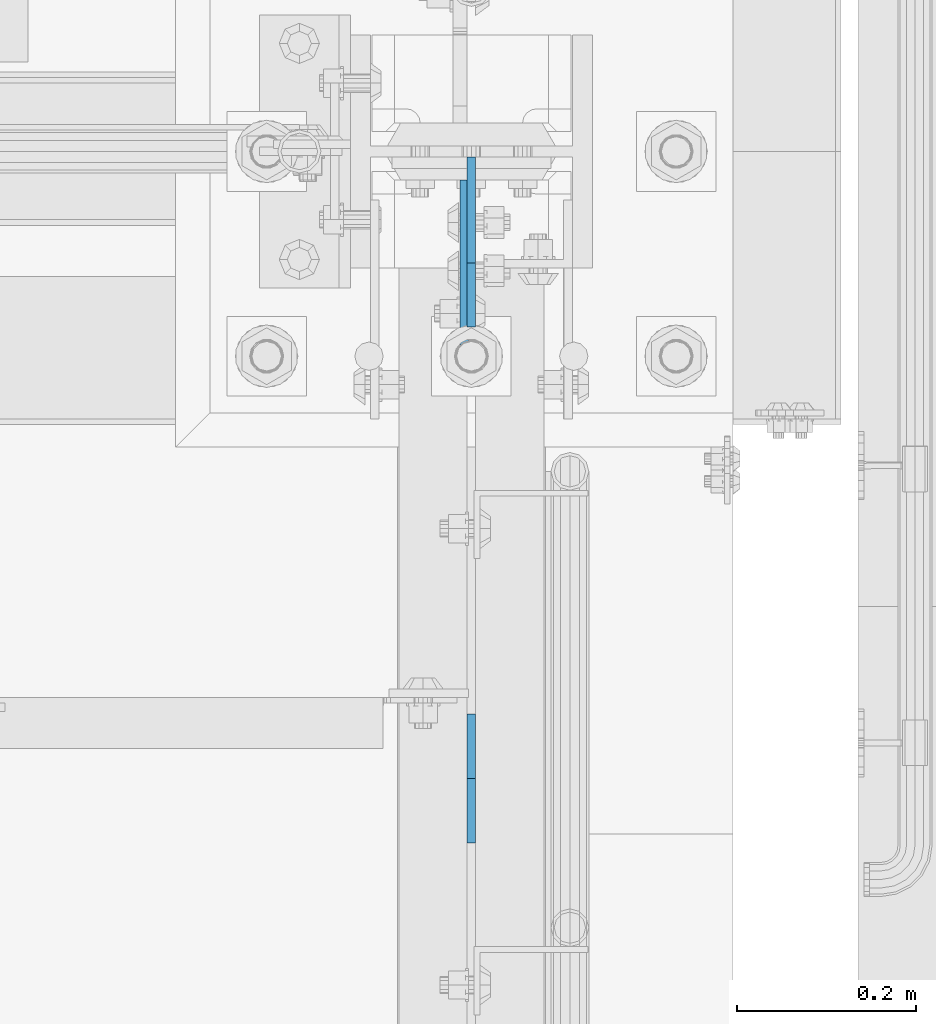
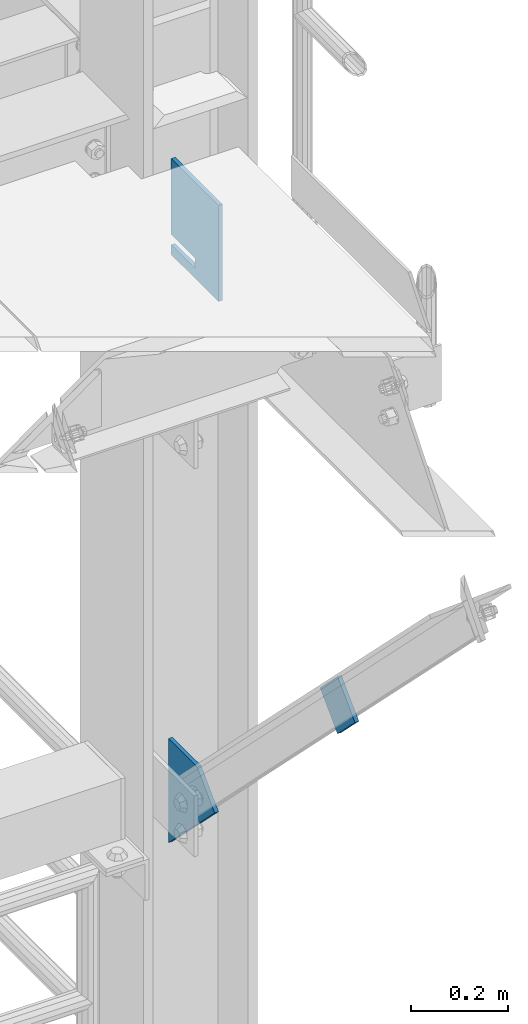
# One storey, part 1519 of 1876: 3 plates, 2 elements without a shape of their own.
"""IFC2X3 building model written with IfcOpenShell, lengths in millimetres."""

from ifc_helpers import new_model, si_unit, frame, origin_with_axes, place, context, subcontext, project, spatial, faceted_brep, material, type_object, element, aggregate, save


model = new_model("IFC2X3")

# Units and contexts
model_context = context("Model", 3, precision=1e-05, world=origin_with_axes())
body_context = subcontext(model_context, "Body", "Model", "MODEL_VIEW")
ifc_project = project(units=[si_unit("LENGTHUNIT", "METRE", prefix="MILLI"), si_unit("AREAUNIT", "SQUARE_METRE"), si_unit("VOLUMEUNIT", "CUBIC_METRE"), si_unit("MASSUNIT", "GRAM", prefix="KILO"), si_unit("TIMEUNIT", "SECOND"), si_unit("PLANEANGLEUNIT", "RADIAN"), si_unit("SOLIDANGLEUNIT", "STERADIAN"), si_unit("THERMODYNAMICTEMPERATUREUNIT", "DEGREE_CELSIUS"), si_unit("LUMINOUSINTENSITYUNIT", "LUMEN")], contexts=[model_context])

# Site, building, storey
site_placement = place(None, origin_with_axes())
site = spatial("IfcSite", under=ifc_project, at=site_placement, CompositionType="ELEMENT")
building_placement = place(site_placement, origin_with_axes())
building = spatial("IfcBuilding", under=site, at=building_placement, Name="Undefined", CompositionType="ELEMENT")
storey_placement = place(building_placement, origin_with_axes())
storey = spatial("IfcBuildingStorey", under=building, at=storey_placement, Name="Undefined", CompositionType="ELEMENT", Elevation=0.0)

# Assembly, plate
assembly_1_placement = place(storey_placement, origin_with_axes())
assembly_1 = element("IfcElementAssembly", 1, at=assembly_1_placement, inside=storey, Name="ANGLE", AssemblyPlace="NOTDEFINED", PredefinedType="RIGID_FRAME")
ifc_material_1 = material(Name="STEEL/A36")
plate_type_1 = type_object("IfcPlateType", PredefinedType="NOTDEFINED")
plate_1_placement = place(assembly_1_placement, frame((7620.0, -7812.08750000563, 7064.7795489681), z_axis=(0.0, 0.707106781186548, -0.707106781186548), x_axis=(0.0, -0.707106781186548, -0.707106781186548)))
plate_1 = element("IfcPlate", 2, at=plate_1_placement, type_object=plate_type_1, material=ifc_material_1, Name="PLATE", context=body_context, shape_type="Brep", body=[
    faceted_brep([(0.0, -4.76249999999982, 0.0), (-2.38742359215394e-12, -4.76249999999982, 101.599998474137), (-2.38742359215394e-12, 4.76249999999982, 101.599998474137), (0.0, 4.76249999999982, 0.0), (101.599998474137, -4.76249999999982, 101.599998474137), (101.599998474137, 4.76249999999982, 101.599998474137), (101.599998474138, -4.76249999999982, -1.81898940354586e-12), (101.599998474138, 4.76249999999982, -1.81898940354586e-12)], [[[0, 1, 2, 3]], [[1, 4, 5, 2]], [[4, 6, 7, 5]], [[6, 0, 3, 7]], [[5, 7, 3, 2]], [[6, 4, 1, 0]]]),
])
aggregate(assembly_1, [plate_1])

# Assembly, plates
assembly_2_placement = place(storey_placement, origin_with_axes())
assembly_2 = element("IfcElementAssembly", 3, at=assembly_2_placement, inside=storey, Name="COLUMN", AssemblyPlace="NOTDEFINED", PredefinedType="RIGID_FRAME")
plate_type_2 = type_object("IfcPlateType", PredefinedType="NOTDEFINED")
plate_2_placement = place(assembly_2_placement, frame((7620.0, -7236.27628060535, 6488.96832956781), z_axis=(0.0, 0.707106781186548, -0.707106781186548), x_axis=(0.0, -0.707106781186548, -0.707106781186548)))
plate_2 = element("IfcPlate", 4, at=plate_2_placement, type_object=plate_type_2, material=ifc_material_1, Name="PLATE", context=body_context, shape_type="Brep", body=[
    faceted_brep([(0.0, -4.76249999999982, 0.0), (-83.3864746093888, -4.76249999999982, 83.3864746093914), (-83.3864746093888, 4.76249999999982, 83.3864746093914), (0.0, 4.76249999999982, 0.0), (101.599998474139, -4.76249999999982, 268.372955322311), (101.599998474139, 4.76249999999982, 268.372955322311), (101.599998474138, -4.76249999999982, -1.81898940354586e-12), (101.599998474138, 4.76249999999982, -1.81898940354586e-12)], [[[0, 1, 2, 3]], [[1, 4, 5, 2]], [[4, 6, 7, 5]], [[6, 0, 3, 7]], [[5, 7, 3, 2]], [[6, 4, 1, 0]]]),
])
ifc_material_2 = material(Name="STEEL/A572-50")
plate_type_3 = type_object("IfcPlateType", PredefinedType="NOTDEFINED")
plate_3_placement = place(assembly_2_placement, frame((7612.06299991608, -7143.75, 7959.725), z_axis=(0.0, -1.0, 0.0), x_axis=(0.0, 0.0, -1.0)))
plate_3 = element("IfcPlate", 5, at=plate_3_placement, type_object=plate_type_3, material=ifc_material_2, Name="PLATE", context=body_context, shape_type="Brep", body=[
    faceted_brep([(190.5, -4.76249999999982, 0.0), (190.5, 4.76249999999982, 0.0), (190.5, 4.76249999999982, 98.4250030517578), (190.5, -4.76249999999982, 98.4250030517578), (215.899988174438, -4.76249999999982, 98.4250030517578), (215.899988174438, 4.76249999999982, 98.4250030517578), (215.899988174438, 4.76249999999982, 0.0), (215.899988174438, -4.76249999999982, 0.0), (0.0, -4.76249999999982, 0.0), (0.0, -4.76249999999982, 193.675003051758), (0.0, 4.76249999999982, 193.675003051758), (0.0, 4.76249999999982, 0.0), (241.299987792969, -4.76249999999982, 193.675003051758), (241.299987792969, 4.76249999999982, 193.675003051758), (241.300006866455, -4.76250000000073, -9.09494701772928e-13), (241.300006866455, 4.76250000000073, 4.54747350886464e-13)], [[[0, 1, 2, 3]], [[4, 5, 6, 7]], [[3, 2, 5, 4]], [[8, 9, 10, 11]], [[9, 12, 13, 10]], [[12, 14, 15, 13]], [[15, 14, 7, 6]], [[1, 11, 10, 13, 15, 6, 5, 2]], [[8, 11, 1, 0]], [[14, 12, 9, 8, 0, 3, 4, 7]]]),
])
aggregate(assembly_2, [plate_2, plate_3])

save(model, "model.ifc")
